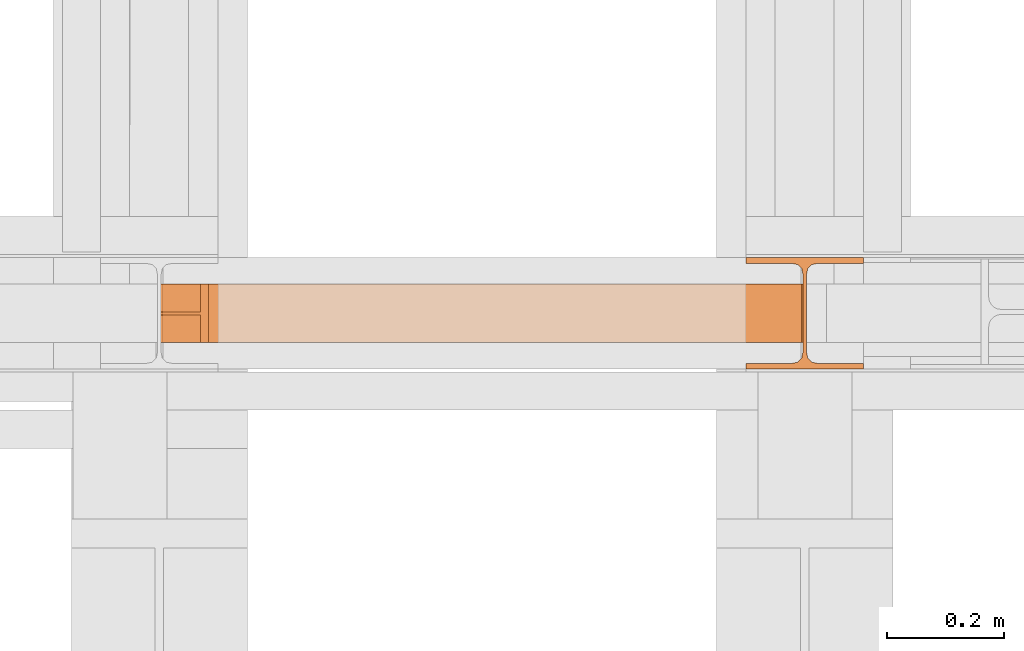
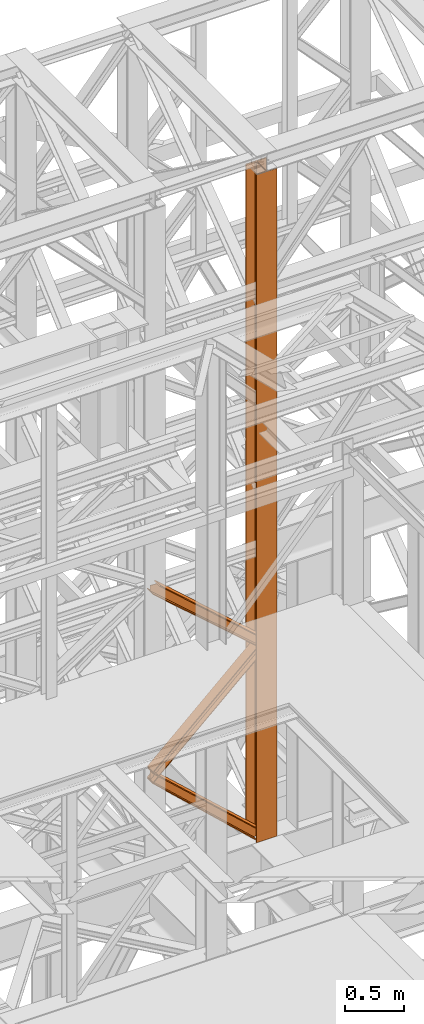
# One storey, part 153 of 208: 4 proxies.
"""IFC2X3 building model written with IfcOpenShell, lengths in millimetres."""

from ifc_helpers import new_model, entity, si_unit, converted_unit, frame, origin, origin_with_axes, place, context, subcontext, project, spatial, faceted_brep, element, save


model = new_model("IFC2X3")

# Units and contexts
model_context = context("Model", 3, precision=1e-05, world=origin())
plan_context = context("Plan", 3, precision=1e-05, world=origin())
body_context = subcontext(model_context, "Body", "Model", "MODEL_VIEW")
ifc_project = project(units=[si_unit("LENGTHUNIT", "METRE", prefix="MILLI"), converted_unit("PLANEANGLEUNIT", "DEGREE", entity("IfcPlaneAngleMeasure", 0.0174532925199433), si_unit("PLANEANGLEUNIT", "RADIAN"), dimensions=[0, 0, 0, 0, 0, 0, 0]), si_unit("AREAUNIT", "SQUARE_METRE"), si_unit("VOLUMEUNIT", "CUBIC_METRE")], contexts=[model_context, plan_context])

# Building, storey
building_placement = place(None, origin())
building = spatial("IfcBuilding", under=ifc_project, at=building_placement, CompositionType="COMPLEX")
storey_placement = place(building_placement, origin_with_axes())
storey = spatial("IfcBuildingStorey", under=building, at=storey_placement, Name="Geschoss", CompositionType="ELEMENT")

# Proxies
proxy_1_placement = place(storey_placement, frame((6493.254967038551, -16057.57439657638, 5284.990005364419), z_axis=(0.0, 0.0, 1.0), x_axis=(1.0, 0.0, 0.0)))
element("IfcBuildingElementProxy", 1, at=proxy_1_placement, inside=storey, context=body_context, shape_type="Brep", body=[
    faceted_brep([(0.009999999999308784, 190.0100125169774, 6965.010053329391), (200.0100029802316, 190.0100125169774, 6965.010053329391), (200.0100029802316, 180.01001460314, 6965.010053329391), (121.260003576278, 180.0100071525594, 6965.010053329391), (111.9441915473335, 178.1454621052762, 6965.010053329391), (105.1245498640828, 171.3258190250417, 6965.010053329391), (103.2600015571707, 162.0100079274198, 6965.010053329391), (103.2600015571707, 28.00999713897909, 6965.010053329391), (105.1245498640828, 18.69418604135717, 6965.010053329391), (111.9441915473335, 11.87454296112264, 6965.010053329391), (121.260003576278, 10.00999791383947, 6965.010053329391), (200.0100029802316, 10.00999791383947, 6965.010053329391), (200.0100029802316, 0.01000000000203727, 6965.010053329391), (0.009999999999308784, 0.01000000000203727, 6965.010053329391), (0.009999999999308784, 10.00999791383947, 6965.010053329391), (78.75999940395286, 10.00999791383947, 6965.010053329391), (88.07581143289735, 11.87454296112264, 6965.010053329391), (94.89545311614802, 18.69418604135717, 6965.010053329391), (96.7600014230602, 28.00999713897909, 6965.010053329391), (96.7600014230602, 162.0100079274198, 6965.010053329391), (94.89545311614802, 171.3258190250417, 6965.010053329391), (88.07581143289735, 178.1454621052762, 6965.010053329391), (78.75999940395286, 180.0100071525594, 6965.010053329391), (0.009999999999308784, 180.01001460314, 6965.010053329391), (200.0100029802316, 190.0100125169774, 6965.010053329391), (0.009999999999308784, 190.0100125169774, 6965.010053329391), (0.01000000000021828, 190.0100125169756, 0.009999999999308784), (200.0100029802325, 190.0100125169756, 0.009999999999308784), (200.0100029802316, 180.01001460314, 6965.010053329391), (200.0100029802316, 190.0100125169774, 6965.010053329391), (200.0100029802325, 190.0100125169756, 0.009999999999308784), (200.0100029802325, 180.0100146031382, 0.009999999999308784), (121.260003576278, 180.0100071525594, 6965.010053329391), (200.0100029802316, 180.01001460314, 6965.010053329391), (200.0100029802325, 180.0100146031382, 0.009999999999308784), (121.2600035762789, 180.0100071525576, 0.009999999999308784), (111.9441915473335, 178.1454621052762, 6965.010053329391), (121.260003576278, 180.0100071525594, 6965.010053329391), (121.2600035762789, 180.0100071525576, 0.009999999999308784), (111.9441915473344, 178.1454621052744, 0.009999999999308784), (105.1245498640828, 171.3258190250417, 6965.010053329391), (111.9441915473335, 178.1454621052762, 6965.010053329391), (111.9441915473344, 178.1454621052744, 0.009999999999308784), (105.1245498640838, 171.3258190250399, 0.009999999999308784), (103.2600015571707, 162.0100079274198, 6965.010053329391), (105.1245498640828, 171.3258190250417, 6965.010053329391), (105.1245498640838, 171.3258190250399, 0.009999999999308784), (103.2600015571716, 162.010007927418, 0.009999999999308784), (103.2600015571707, 28.00999713897909, 6965.010053329391), (103.2600015571707, 162.0100079274198, 6965.010053329391), (103.2600015571716, 162.010007927418, 0.009999999999308784), (103.2600015571716, 28.00999713897727, 0.009999999999308784), (105.1245498640828, 18.69418604135717, 6965.010053329391), (103.2600015571707, 28.00999713897909, 6965.010053329391), (103.2600015571716, 28.00999713897727, 0.009999999999308784), (105.1245498640838, 18.69418604135535, 0.009999999999308784), (111.9441915473335, 11.87454296112264, 6965.010053329391), (105.1245498640828, 18.69418604135717, 6965.010053329391), (105.1245498640838, 18.69418604135535, 0.009999999999308784), (111.9441915473344, 11.87454296112082, 0.009999999999308784), (121.260003576278, 10.00999791383947, 6965.010053329391), (111.9441915473335, 11.87454296112264, 6965.010053329391), (111.9441915473344, 11.87454296112082, 0.009999999999308784), (121.2600035762789, 10.00999791383765, 0.009999999999308784), (200.0100029802316, 10.00999791383947, 6965.010053329391), (121.260003576278, 10.00999791383947, 6965.010053329391), (121.2600035762789, 10.00999791383765, 0.009999999999308784), (200.0100029802325, 10.00999791383765, 0.009999999999308784), (200.0100029802316, 0.01000000000203727, 6965.010053329391), (200.0100029802316, 10.00999791383947, 6965.010053329391), (200.0100029802325, 10.00999791383765, 0.009999999999308784), (200.0100029802325, 0.01000000000021828, 0.009999999999308784), (0.009999999999308784, 0.01000000000203727, 6965.010053329391), (200.0100029802316, 0.01000000000203727, 6965.010053329391), (200.0100029802325, 0.01000000000021828, 0.009999999999308784), (0.01000000000021828, 0.01000000000021828, 0.009999999999308784), (0.009999999999308784, 10.00999791383947, 6965.010053329391), (0.009999999999308784, 0.01000000000203727, 6965.010053329391), (0.01000000000021828, 0.01000000000021828, 0.009999999999308784), (0.01000000000021828, 10.00999791383765, 0.009999999999308784), (78.75999940395286, 10.00999791383947, 6965.010053329391), (0.009999999999308784, 10.00999791383947, 6965.010053329391), (0.01000000000021828, 10.00999791383765, 0.009999999999308784), (78.75999940395377, 10.00999791383765, 0.009999999999308784), (88.07581143289735, 11.87454296112264, 6965.010053329391), (78.75999940395286, 10.00999791383947, 6965.010053329391), (78.75999940395377, 10.00999791383765, 0.009999999999308784), (88.07581143289826, 11.87454296112082, 0.009999999999308784), (94.89545311614802, 18.69418604135717, 6965.010053329391), (88.07581143289735, 11.87454296112264, 6965.010053329391), (88.07581143289826, 11.87454296112082, 0.009999999999308784), (94.89545311614893, 18.69418604135535, 0.009999999999308784), (96.7600014230602, 28.00999713897909, 6965.010053329391), (94.89545311614802, 18.69418604135717, 6965.010053329391), (94.89545311614893, 18.69418604135535, 0.009999999999308784), (96.76000142306111, 28.00999713897727, 0.009999999999308784), (96.7600014230602, 162.0100079274198, 6965.010053329391), (96.7600014230602, 28.00999713897909, 6965.010053329391), (96.76000142306111, 28.00999713897727, 0.009999999999308784), (96.76000142306111, 162.010007927418, 0.009999999999308784), (94.89545311614802, 171.3258190250417, 6965.010053329391), (96.7600014230602, 162.0100079274198, 6965.010053329391), (96.76000142306111, 162.010007927418, 0.009999999999308784), (94.89545311614893, 171.3258190250399, 0.009999999999308784), (88.07581143289735, 178.1454621052762, 6965.010053329391), (94.89545311614802, 171.3258190250417, 6965.010053329391), (94.89545311614893, 171.3258190250399, 0.009999999999308784), (88.07581143289826, 178.1454621052744, 0.009999999999308784), (78.75999940395286, 180.0100071525594, 6965.010053329391), (88.07581143289735, 178.1454621052762, 6965.010053329391), (88.07581143289826, 178.1454621052744, 0.009999999999308784), (78.75999940395377, 180.0100071525576, 0.009999999999308784), (0.009999999999308784, 180.01001460314, 6965.010053329391), (78.75999940395286, 180.0100071525594, 6965.010053329391), (78.75999940395377, 180.0100071525576, 0.009999999999308784), (0.01000000000021828, 180.0100146031382, 0.009999999999308784), (0.009999999999308784, 190.0100125169774, 6965.010053329391), (0.009999999999308784, 180.01001460314, 6965.010053329391), (0.01000000000021828, 180.0100146031382, 0.009999999999308784), (0.01000000000021828, 190.0100125169756, 0.009999999999308784), (0.01000000000021828, 190.0100125169756, 0.009999999999308784), (0.01000000000021828, 180.0100146031382, 0.009999999999308784), (78.75999940395377, 180.0100071525576, 0.009999999999308784), (88.07581143289826, 178.1454621052744, 0.009999999999308784), (94.89545311614893, 171.3258190250399, 0.009999999999308784), (96.76000142306111, 162.010007927418, 0.009999999999308784), (96.76000142306111, 28.00999713897727, 0.009999999999308784), (94.89545311614893, 18.69418604135535, 0.009999999999308784), (88.07581143289826, 11.87454296112082, 0.009999999999308784), (78.75999940395377, 10.00999791383765, 0.009999999999308784), (0.01000000000021828, 10.00999791383765, 0.009999999999308784), (0.01000000000021828, 0.01000000000021828, 0.009999999999308784), (200.0100029802325, 0.01000000000021828, 0.009999999999308784), (200.0100029802325, 10.00999791383765, 0.009999999999308784), (121.2600035762789, 10.00999791383765, 0.009999999999308784), (111.9441915473344, 11.87454296112082, 0.009999999999308784), (105.1245498640838, 18.69418604135535, 0.009999999999308784), (103.2600015571716, 28.00999713897727, 0.009999999999308784), (103.2600015571716, 162.010007927418, 0.009999999999308784), (105.1245498640838, 171.3258190250399, 0.009999999999308784), (111.9441915473344, 178.1454621052744, 0.009999999999308784), (121.2600035762789, 180.0100071525576, 0.009999999999308784), (200.0100029802325, 180.0100146031382, 0.009999999999308784), (200.0100029802325, 190.0100125169756, 0.009999999999308784)], [[[0, 1, 2, 3, 4, 5, 6, 7, 8, 9, 10, 11, 12, 13, 14, 15, 16, 17, 18, 19, 20, 21, 22, 23]], [[24, 25, 26, 27]], [[28, 29, 30, 31]], [[32, 33, 34, 35]], [[36, 37, 38, 39]], [[40, 41, 42, 43]], [[44, 45, 46, 47]], [[48, 49, 50, 51]], [[52, 53, 54, 55]], [[56, 57, 58, 59]], [[60, 61, 62, 63]], [[64, 65, 66, 67]], [[68, 69, 70, 71]], [[72, 73, 74, 75]], [[76, 77, 78, 79]], [[80, 81, 82, 83]], [[84, 85, 86, 87]], [[88, 89, 90, 91]], [[92, 93, 94, 95]], [[96, 97, 98, 99]], [[100, 101, 102, 103]], [[104, 105, 106, 107]], [[108, 109, 110, 111]], [[112, 113, 114, 115]], [[116, 117, 118, 119]], [[120, 121, 122, 123, 124, 125, 126, 127, 128, 129, 130, 131, 132, 133, 134, 135, 136, 137, 138, 139, 140, 141, 142, 143]]], orient=[[False], [False], [False], [False], [False], [False], [False], [False], [False], [False], [False], [False], [False], [False], [False], [False], [False], [False], [False], [False], [False], [False], [False], [False], [False], [False]]),
])
proxy_2_placement = place(storey_placement, frame((5495.439888909068, -16012.50587051042, 5284.990005364412), z_axis=(0.0, 0.0, 1.0), x_axis=(1.0, 0.0, 0.0)))
element("IfcBuildingElementProxy", 2, at=proxy_2_placement, inside=storey, context=body_context, shape_type="Brep", body=[
    faceted_brep([(0.01000000000021828, 0.01000000000021828, 946.119090083349), (1021.597917352437, 0.01000000001477019, 0.01000000000749424), (1007.941580287223, 0.01000000000021828, 0.01000000000749424), (0.01000000000021828, 0.01000000000021828, 936.458735125886), (0.01000000000021828, 0.01000000000021828, 936.458735125886), (1007.941580287223, 0.01000000000021828, 0.01000000000749424), (1007.941580287223, 100.0100000000075, 0.01000000000021828), (0.01000000000021828, 100.0100000000075, 936.4587351258824), (0.01000000000021828, 100.0100000000075, 936.4587351258824), (1007.941580287223, 100.0100000000075, 0.01000000000021828), (1021.597917352437, 100.0100000000148, 0.01000000000749424), (0.01000000000021828, 100.0100000000002, 946.119090083349), (0.01000000000021828, 100.0100000000002, 946.119090083349), (1021.597917352437, 100.0100000000148, 0.01000000000749424), (1021.597917352452, 52.51000000001477, 0.01000000000021828), (0.01000000000021828, 52.51000000000749, 946.1190900833453), (0.01000000000021828, 52.51000000000749, 946.1190900833453), (1021.597917352452, 52.51000000001477, 0.01000000000021828), (1094.575079552544, 52.51000000001477, 0.01000000000749424), (1094.575079552551, 52.51000000001477, 44.72914894897076), (3.506126526333901, 52.51000000000022, 1040.447505870337), (0.01000000000021828, 52.51000000000022, 1040.385034696505), (3.506126526333901, 52.51000000000022, 1040.447505870337), (1094.575079552551, 52.51000000001477, 44.72914894897076), (1094.575079552551, 100.0100000000075, 44.72914894897076), (3.506126526333901, 100.0100000000002, 1040.447505870334), (3.506126526333901, 100.0100000000002, 1040.447505870334), (1094.575079552551, 100.0100000000075, 44.72914894897076), (1094.575079552551, 100.0100000000075, 54.33717683089162), (16.91845998294411, 100.0100000000002, 1040.687166594451), (16.91845998294411, 100.0100000000002, 1040.687166594451), (1094.575079552551, 100.0100000000075, 54.33717683089162), (1094.575079552551, 0.01000000001477019, 54.33717683089162), (16.91845998294411, 0.01000000000021828, 1040.687166594451), (16.91845998294411, 0.01000000000021828, 1040.687166594451), (1094.575079552551, 0.01000000001477019, 54.33717683089162), (1094.575079552551, 0.01000000001477019, 44.72914894897076), (3.506126526333901, 0.01000000000021828, 1040.447505870337), (3.506126526333901, 0.01000000000021828, 1040.447505870337), (1094.575079552551, 0.01000000001477019, 44.72914894897076), (1094.575079552551, 47.51000000001477, 44.72914894897076), (3.506126526333901, 47.51000000000022, 1040.447505870334), (3.506126526333901, 47.51000000000022, 1040.447505870334), (1094.575079552551, 47.51000000001477, 44.72914894897076), (1094.575079552558, 47.51000000002205, 0.01000000000749424), (1021.597917352437, 47.51000000001477, 0.01000000000749424), (0.01000000000021828, 47.51000000000022, 946.119090083348), (0.01000000000021828, 47.51000000000022, 1040.3850346965), (0.01000000000021828, 47.51000000000022, 946.119090083348), (1021.597917352437, 47.51000000001477, 0.01000000000749424), (1021.597917352437, 0.01000000001477019, 0.01000000000749424), (0.01000000000021828, 0.01000000000021828, 946.119090083349), (0.01000000000021828, 52.51000000000022, 1040.385034696505), (3.506126526333901, 52.51000000000022, 1040.447505870337), (3.506126526333901, 100.0100000000002, 1040.447505870334), (16.91845998294411, 100.0100000000002, 1040.687166594451), (16.91845998294411, 0.01000000000021828, 1040.687166594451), (3.506126526333901, 0.01000000000021828, 1040.447505870337), (3.506126526333901, 47.51000000000022, 1040.447505870334), (0.01000000000021828, 47.51000000000022, 1040.3850346965), (1094.575079552558, 47.51000000002205, 0.01000000000749424), (1094.575079552551, 47.51000000001477, 44.72914894897076), (1094.575079552551, 0.01000000001477019, 44.72914894897076), (1094.575079552551, 0.01000000001477019, 54.33717683089162), (1094.575079552551, 100.0100000000075, 54.33717683089162), (1094.575079552551, 100.0100000000075, 44.72914894897076), (1094.575079552551, 52.51000000001477, 44.72914894897076), (1094.575079552544, 52.51000000001477, 0.01000000000749424), (1021.597917352437, 0.01000000001477019, 0.01000000000749424), (1021.597917352437, 47.51000000001477, 0.01000000000749424), (1094.575079552558, 47.51000000002205, 0.01000000000749424), (1094.575079552544, 52.51000000001477, 0.01000000000749424), (1021.597917352452, 52.51000000001477, 0.01000000000021828), (1021.597917352437, 100.0100000000148, 0.01000000000749424), (1007.941580287223, 100.0100000000075, 0.01000000000021828), (1007.941580287223, 0.01000000000021828, 0.01000000000749424), (0.01000000000021828, 0.01000000000021828, 936.458735125886), (0.01000000000021828, 100.0100000000075, 936.4587351258824), (0.01000000000021828, 100.0100000000002, 946.119090083349), (0.01000000000021828, 52.51000000000749, 946.1190900833453), (0.01000000000021828, 52.51000000000022, 1040.385034696505), (0.01000000000021828, 47.51000000000022, 1040.3850346965), (0.01000000000021828, 47.51000000000022, 946.119090083348), (0.01000000000021828, 0.01000000000021828, 946.119090083349)], [[[0, 1, 2, 3]], [[4, 5, 6, 7]], [[8, 9, 10, 11]], [[12, 13, 14, 15]], [[16, 17, 18, 19, 20, 21]], [[22, 23, 24, 25]], [[26, 27, 28, 29]], [[30, 31, 32, 33]], [[34, 35, 36, 37]], [[38, 39, 40, 41]], [[42, 43, 44, 45, 46, 47]], [[48, 49, 50, 51]], [[52, 53, 54, 55, 56, 57, 58, 59]], [[60, 61, 62, 63, 64, 65, 66, 67]], [[68, 69, 70, 71, 72, 73, 74, 75]], [[76, 77, 78, 79, 80, 81, 82, 83]]], orient=[[False], [False], [False], [False], [False], [False], [False], [False], [False], [False], [False], [False], [False], [False], [False], [False]]),
])
proxy_3_placement = place(storey_placement, frame((5498.369516902635, -16012.50587051044, 6225.75821453775), z_axis=(0.0, 0.0, 1.0), x_axis=(1.0, 0.0, 0.0)))
element("IfcBuildingElementProxy", 3, at=proxy_3_placement, inside=storey, context=body_context, shape_type="Brep", body=[
    faceted_brep([(0.01000000000658474, 0.01000000000749424, 119.7739453356198), (1091.645451558976, 0.01000000002204615, 1120.838175190878), (1091.645451558976, 0.01000000002204615, 1110.806590765606), (0.01000000000658474, 0.01000000000021828, 109.7936165576475), (0.009999999999308784, 100.0100000000002, 119.7739453356162), (1091.645451558976, 100.0100000000221, 1120.838175190878), (1091.645451558976, 0.01000000002204615, 1120.838175190878), (0.01000000000658474, 0.01000000000749424, 119.7739453356198), (0.009999999999308784, 100.0100000000002, 109.7936165576475), (1091.645451558976, 100.0100000000221, 1110.806590765614), (1091.645451558976, 100.0100000000221, 1120.838175190878), (0.009999999999308784, 100.0100000000002, 119.7739453356162), (0.009999999999308784, 52.51000000000022, 109.7936165576439), (1091.645451558976, 52.51000000002205, 1110.806590765606), (1091.645451558976, 100.0100000000221, 1110.806590765614), (0.009999999999308784, 100.0100000000002, 109.7936165576475), (0.009999999999308784, 52.51000000000749, 9.99032877796435), (1091.645451558976, 52.51000000002205, 1010.49274210871), (1091.645451558976, 52.51000000002205, 1110.806590765606), (0.009999999999308784, 52.51000000000022, 109.7936165576439), (0.009999999999308784, 100.0100000000075, 9.990328777967989), (1091.645451558976, 100.0100000000221, 1010.492742108708), (1091.645451558976, 52.51000000002205, 1010.49274210871), (0.009999999999308784, 52.51000000000749, 9.99032877796435), (0.009999999999308784, 100.0100000000075, 0.01000000000294676), (1091.645451558976, 100.0100000000221, 1000.461555955297), (1091.645451558976, 100.0100000000221, 1010.492742108708), (0.009999999999308784, 100.0100000000075, 9.990328777967989), (0.01000000000658474, 0.01000000000749424, 0.009999999999308784), (1091.645451558976, 0.01000000002204615, 1000.461555955297), (1091.645451558976, 100.0100000000221, 1000.461555955297), (0.009999999999308784, 100.0100000000075, 0.01000000000294676), (0.009999999999308784, 0.01000000000021828, 9.99032877796435), (1091.645451558976, 0.01000000002204615, 1010.492742108704), (1091.645451558976, 0.01000000002204615, 1000.461555955297), (0.01000000000658474, 0.01000000000749424, 0.009999999999308784), (0.009999999999308784, 47.51000000000749, 9.990328777967989), (1091.645451558976, 47.51000000002205, 1010.492742108704), (1091.645451558976, 0.01000000002204615, 1010.492742108704), (0.009999999999308784, 0.01000000000021828, 9.99032877796435), (0.01000000000658474, 47.51000000000022, 109.7936165576439), (1091.645451558976, 47.51000000002205, 1110.806590765606), (1091.645451558976, 47.51000000002205, 1010.492742108704), (0.009999999999308784, 47.51000000000749, 9.990328777967989), (0.01000000000658474, 0.01000000000021828, 109.7936165576475), (1091.645451558976, 0.01000000002204615, 1110.806590765606), (1091.645451558976, 47.51000000002205, 1110.806590765606), (0.01000000000658474, 47.51000000000022, 109.7936165576439), (0.01000000000658474, 0.01000000000021828, 109.7936165576475), (0.01000000000658474, 47.51000000000022, 109.7936165576439), (0.009999999999308784, 47.51000000000749, 9.990328777967989), (0.009999999999308784, 0.01000000000021828, 9.99032877796435), (0.01000000000658474, 0.01000000000749424, 0.009999999999308784), (0.009999999999308784, 100.0100000000075, 0.01000000000294676), (0.009999999999308784, 100.0100000000075, 9.990328777967989), (0.009999999999308784, 52.51000000000749, 9.99032877796435), (0.009999999999308784, 52.51000000000022, 109.7936165576439), (0.009999999999308784, 100.0100000000002, 109.7936165576475), (0.009999999999308784, 100.0100000000002, 119.7739453356162), (0.01000000000658474, 0.01000000000749424, 119.7739453356198), (1091.645451558976, 0.01000000002204615, 1120.838175190878), (1091.645451558976, 100.0100000000221, 1120.838175190878), (1091.645451558976, 100.0100000000221, 1110.806590765614), (1091.645451558976, 52.51000000002205, 1110.806590765606), (1091.645451558976, 52.51000000002205, 1010.49274210871), (1091.645451558976, 100.0100000000221, 1010.492742108708), (1091.645451558976, 100.0100000000221, 1000.461555955297), (1091.645451558976, 0.01000000002204615, 1000.461555955297), (1091.645451558976, 0.01000000002204615, 1010.492742108704), (1091.645451558976, 47.51000000002205, 1010.492742108704), (1091.645451558976, 47.51000000002205, 1110.806590765606), (1091.645451558976, 0.01000000002204615, 1110.806590765606)], [[[0, 1, 2, 3]], [[4, 5, 6, 7]], [[8, 9, 10, 11]], [[12, 13, 14, 15]], [[16, 17, 18, 19]], [[20, 21, 22, 23]], [[24, 25, 26, 27]], [[28, 29, 30, 31]], [[32, 33, 34, 35]], [[36, 37, 38, 39]], [[40, 41, 42, 43]], [[44, 45, 46, 47]], [[48, 49, 50, 51, 52, 53, 54, 55, 56, 57, 58, 59]], [[60, 61, 62, 63, 64, 65, 66, 67, 68, 69, 70, 71]]], orient=[[False], [False], [False], [False], [False], [False], [False], [False], [False], [False], [False], [False], [False], [False]]),
])
proxy_4_placement = place(storey_placement, frame((5495.439888909066, -16012.50587051045, 7239.039211299423), z_axis=(0.0, 0.0, 1.0), x_axis=(1.0, 0.0, 0.0)))
element("IfcBuildingElementProxy", 4, at=proxy_4_placement, inside=storey, context=body_context, shape_type="Brep", body=[
    faceted_brep([(0.01000000000021828, 0.01000000000203727, 966.7564815021651), (1092.710531245633, 0.01000000002204615, 9.99032877796526), (1092.710531245626, 0.01000000002932211, 0.01000000000021828), (0.01000000000112777, 0.01000000000203727, 955.6421024533101), (0.01000000000112777, 0.01000000000203727, 955.6421024533101), (1092.710531245626, 0.01000000002932211, 0.01000000000021828), (1092.710531245626, 100.0100000000293, 0.01000000000021828), (0.01000000000203727, 100.010000000002, 955.6421024533101), (0.01000000000203727, 100.010000000002, 955.6421024533101), (1092.710531245626, 100.0100000000293, 0.01000000000021828), (1092.710531245633, 100.0100000000293, 9.99032877796526), (0.01000000000203727, 100.010000000002, 966.7564815021651), (0.01000000000203727, 100.010000000002, 966.7564815021651), (1092.710531245633, 100.0100000000293, 9.99032877796526), (1092.710531245633, 52.51000000002205, 9.99032877796526), (0.01000000000112777, 52.51000000000204, 966.7564815021651), (0.01000000000112777, 52.51000000000204, 966.7564815021651), (1092.710531245633, 52.51000000002205, 9.99032877796526), (1092.710531245633, 52.51000000002932, 109.7936165576448), (68.0931977361106, 52.51000000000022, 1019.110372209218), (0.01000000000112777, 52.51000000000022, 1021.850459002717), (68.0931977361106, 52.51000000000022, 1019.110372209218), (1092.710531245633, 52.51000000002932, 109.7936165576448), (1092.710531245633, 100.0100000000293, 109.7936165576448), (68.0931977361106, 100.0100000000002, 1019.110372209214), (68.0931977361106, 100.0100000000002, 1019.110372209214), (1092.710531245633, 100.0100000000293, 109.7936165576448), (1092.710531245633, 100.0100000000293, 119.7739453356062), (81.49682134599425, 100.0100000000002, 1018.570927922525), (81.49682134599425, 100.0100000000002, 1018.570927922525), (1092.710531245633, 100.0100000000293, 119.7739453356062), (1092.710531245633, 0.01000000002932211, 119.7739453356135), (81.49682134599425, 0.01000000000021828, 1018.570927922525), (81.49682134599425, 0.01000000000021828, 1018.570927922525), (1092.710531245633, 0.01000000002932211, 119.7739453356135), (1092.710531245633, 0.01000000002932211, 109.7936165576448), (68.0931977361106, 0.01000000000021828, 1019.110372209218), (68.0931977361106, 0.01000000000021828, 1019.110372209218), (1092.710531245633, 0.01000000002932211, 109.7936165576448), (1092.710531245633, 47.51000000002932, 109.7936165576448), (68.0931977361106, 47.51000000000022, 1019.110372209214), (68.0931977361106, 47.51000000000022, 1019.110372209214), (1092.710531245633, 47.51000000002932, 109.7936165576448), (1092.710531245633, 47.51000000002932, 9.990328777961622), (0.01000000000203727, 47.51000000000204, 966.7564815021651), (0.01000000000203727, 47.51000000000022, 1021.850459002715), (0.01000000000203727, 47.51000000000204, 966.7564815021651), (1092.710531245633, 47.51000000002932, 9.990328777961622), (1092.710531245633, 0.01000000002204615, 9.99032877796526), (0.01000000000021828, 0.01000000000203727, 966.7564815021651), (0.01000000000112777, 52.51000000000022, 1021.850459002717), (68.0931977361106, 52.51000000000022, 1019.110372209218), (68.0931977361106, 100.0100000000002, 1019.110372209214), (81.49682134599425, 100.0100000000002, 1018.570927922525), (81.49682134599425, 0.01000000000021828, 1018.570927922525), (68.0931977361106, 0.01000000000021828, 1019.110372209218), (68.0931977361106, 47.51000000000022, 1019.110372209214), (0.01000000000203727, 47.51000000000022, 1021.850459002715), (1092.710531245633, 0.01000000002204615, 9.99032877796526), (1092.710531245633, 47.51000000002932, 9.990328777961622), (1092.710531245633, 47.51000000002932, 109.7936165576448), (1092.710531245633, 0.01000000002932211, 109.7936165576448), (1092.710531245633, 0.01000000002932211, 119.7739453356135), (1092.710531245633, 100.0100000000293, 119.7739453356062), (1092.710531245633, 100.0100000000293, 109.7936165576448), (1092.710531245633, 52.51000000002932, 109.7936165576448), (1092.710531245633, 52.51000000002205, 9.99032877796526), (1092.710531245633, 100.0100000000293, 9.99032877796526), (1092.710531245626, 100.0100000000293, 0.01000000000021828), (1092.710531245626, 0.01000000002932211, 0.01000000000021828), (0.01000000000112777, 0.01000000000203727, 955.6421024533101), (0.01000000000203727, 100.010000000002, 955.6421024533101), (0.01000000000203727, 100.010000000002, 966.7564815021651), (0.01000000000112777, 52.51000000000204, 966.7564815021651), (0.01000000000112777, 52.51000000000022, 1021.850459002717), (0.01000000000203727, 47.51000000000022, 1021.850459002715), (0.01000000000203727, 47.51000000000204, 966.7564815021651), (0.01000000000021828, 0.01000000000203727, 966.7564815021651)], [[[0, 1, 2, 3]], [[4, 5, 6, 7]], [[8, 9, 10, 11]], [[12, 13, 14, 15]], [[16, 17, 18, 19, 20]], [[21, 22, 23, 24]], [[25, 26, 27, 28]], [[29, 30, 31, 32]], [[33, 34, 35, 36]], [[37, 38, 39, 40]], [[41, 42, 43, 44, 45]], [[46, 47, 48, 49]], [[50, 51, 52, 53, 54, 55, 56, 57]], [[58, 59, 60, 61, 62, 63, 64, 65, 66, 67, 68, 69]], [[70, 71, 72, 73, 74, 75, 76, 77]]], orient=[[False], [False], [False], [False], [False], [False], [False], [False], [False], [False], [False], [False], [False], [False], [False]]),
])

save(model, "model.ifc")
